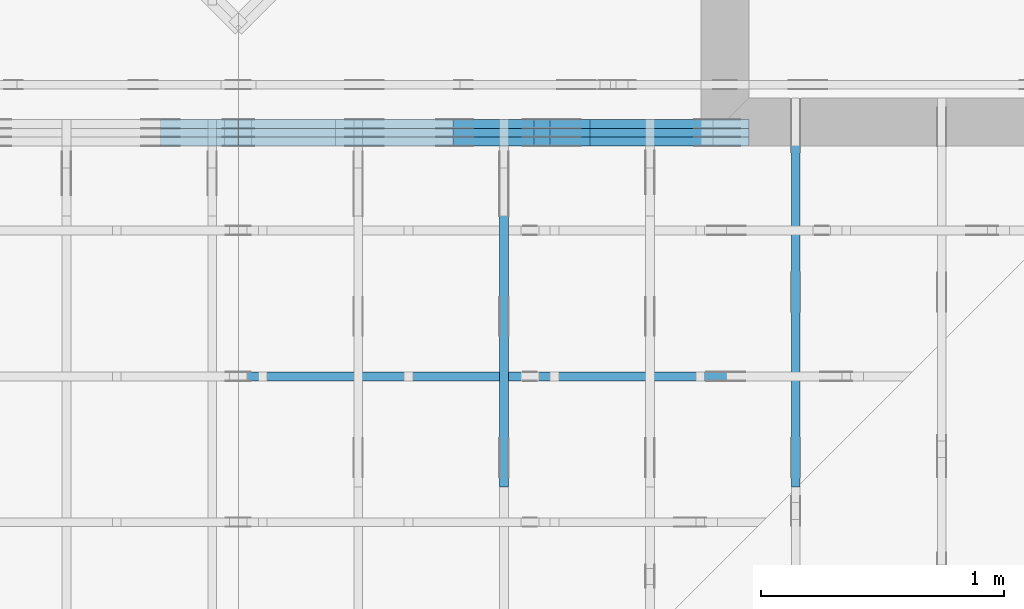
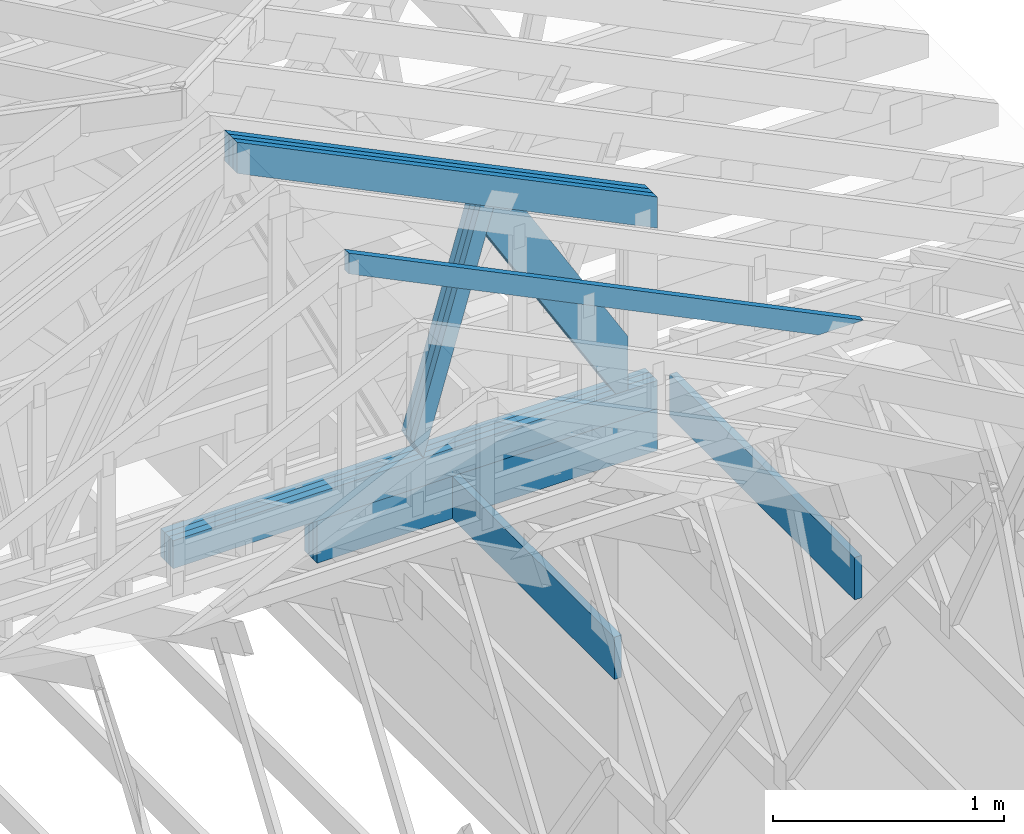
# One storey, part 36 of 159: 18 members, 4 elements without a shape of their own.
"""IFC2X3 building model written with IfcOpenShell, lengths in millimetres."""

import ifcopenshell
import ifcopenshell.guid

model = None  # the IFC model being written
_history = None  # IfcOwnerHistory: only IFC2X3 demands one
_inside = {}  # id of a spatial element -> (the spatial element, [elements in it])
_under = {}  # id of a project, library or spatial element -> (it, [spatial elements below it])
_declared = {}  # id of a project -> (the project, [libraries it declares])
_typed = {}  # id of a type object -> (the type object, [elements of that type])
_made_of = {}  # id of a material, layer set ... -> (it, [elements and type objects made of it])


def new_model(schema):
    """Start an empty IFC model of exactly this schema.

    Asked for "IFC4X3", IfcOpenShell would pick the latest addendum, in which some entities
    have other attributes; the version numbers below select the first issue.
    IFC2X3 requires an IfcOwnerHistory on every rooted entity: one is made here for all.
    """
    global model, _history
    if schema == "IFC4X3":
        model = ifcopenshell.file(schema_version=(4, 3, 0, 0))
    else:
        model = ifcopenshell.file(schema=schema)
    _inside.clear()
    _under.clear()
    _declared.clear()
    _typed.clear()
    _made_of.clear()
    _history = None
    if model.schema == "IFC2X3":
        org = make("IfcOrganization", Name="unknown")
        user = make(
            "IfcPersonAndOrganization",
            ThePerson=make("IfcPerson", FamilyName="unknown"),
            TheOrganization=org,
        )
        app = make(
            "IfcApplication",
            ApplicationDeveloper=org,
            Version="unknown",
            ApplicationFullName="unknown",
            ApplicationIdentifier="unknown",
        )
        _history = make(
            "IfcOwnerHistory",
            OwningUser=user,
            OwningApplication=app,
            ChangeAction="ADDED",
            CreationDate=0,
        )
    return model


def make(cls, **values):
    """One entity of the class cls with the attributes given. An attribute that is None is left unset."""
    return model.create_entity(
        cls, **{name: value for name, value in values.items() if value is not None}
    )


def rooted(cls, **values):
    """An entity with a GlobalId (a new one), such as an element, a storey or a relation."""
    return make(cls, GlobalId=ifcopenshell.guid.new(), OwnerHistory=_history, **values)


def si_unit(unit_type, name, prefix=None):
    """IfcSIUnit, for example si_unit("LENGTHUNIT", "METRE", prefix="MILLI")."""
    return make("IfcSIUnit", UnitType=unit_type, Prefix=prefix, Name=name)


def assignment(units):
    """IfcUnitAssignment: the units of a project."""
    return None if units is None else make("IfcUnitAssignment", Units=units)


def point(xyz):
    """IfcCartesianPoint."""
    return None if xyz is None else make("IfcCartesianPoint", Coordinates=xyz)


def direction(xyz):
    """IfcDirection."""
    return None if xyz is None else make("IfcDirection", DirectionRatios=xyz)


def frame(location, z_axis=None, x_axis=None):
    """IfcAxis2Placement3D, a coordinate frame: its origin and axes. An axis left out is left unset."""
    return make(
        "IfcAxis2Placement3D",
        Location=point(location),
        Axis=direction(z_axis),
        RefDirection=direction(x_axis),
    )


def frame_2d(location, x_axis=None):
    """IfcAxis2Placement2D, a coordinate frame in the plane: its origin and x axis."""
    return make(
        "IfcAxis2Placement2D", Location=point(location), RefDirection=direction(x_axis)
    )


def origin():
    """The frame at (0, 0, 0) with its axes left unset."""
    return frame((0.0, 0.0, 0.0))


def origin_with_axes():
    """The frame at (0, 0, 0) with the z axis (0, 0, 1) and the x axis (1, 0, 0) written out."""
    return frame((0.0, 0.0, 0.0), z_axis=(0.0, 0.0, 1.0), x_axis=(1.0, 0.0, 0.0))


def origin_2d():
    """The frame at (0, 0) in the plane with its x axis left unset."""
    return frame_2d((0.0, 0.0))


def place(relative_to, where):
    """IfcLocalPlacement: puts the frame where relative to a parent placement (None: the world)."""
    return make(
        "IfcLocalPlacement", PlacementRelTo=relative_to, RelativePlacement=where
    )


def context(
    kind, dimensions, precision=None, world=None, true_north=None, identifier=None
):
    """IfcGeometricRepresentationContext, for example the 3D "Model" context."""
    return make(
        "IfcGeometricRepresentationContext",
        ContextIdentifier=identifier,
        ContextType=kind,
        CoordinateSpaceDimension=dimensions,
        Precision=precision,
        WorldCoordinateSystem=world,
        TrueNorth=true_north,
    )


def project(units=None, contexts=None):
    """IfcProject with its units and contexts."""
    return rooted(
        "IfcProject",
        Name="project",
        RepresentationContexts=contexts,
        UnitsInContext=assignment(units),
    )


def spatial(cls, under=None, at=None, **own):
    """A site, building, storey or space (cls), placed at a placement, below another one or the project."""
    s = rooted(cls, ObjectPlacement=at, **own)
    if under is not None:
        _under.setdefault(under.id(), (under, []))[1].append(s)
    return s


def faces_of(points, faces, orient=None, outer=None):
    """IfcFace entities. A face is a list of loops; a loop is a list of indices into points, from 0.

    orient and outer hold one flag for each loop. By default every Orientation is true, the
    first loop of a face is its IfcFaceOuterBound and the others are IfcFaceBound.
    """
    made = []
    for i, loops in enumerate(faces):
        bounds = []
        for j, loop in enumerate(loops):
            is_outer = j == 0 if outer is None else outer[i][j]
            bounds.append(
                make(
                    "IfcFaceOuterBound" if is_outer else "IfcFaceBound",
                    Bound=make("IfcPolyLoop", Polygon=[points[k] for k in loop]),
                    Orientation=True if orient is None else orient[i][j],
                )
            )
        made.append(make("IfcFace", Bounds=bounds))
    return made


def faceted_brep(points, faces, orient=None, outer=None, voids=None):
    """IfcFacetedBrep: a solid bounded by flat faces; with voids (closed shells), ...WithVoids."""
    shared = [point(p) for p in points]
    hull = make("IfcClosedShell", CfsFaces=faces_of(shared, faces, orient, outer))
    if voids is None:
        return make("IfcFacetedBrep", Outer=hull)
    return make(
        "IfcFacetedBrepWithVoids",
        Outer=hull,
        Voids=[
            make(cls, CfsFaces=faces_of(shared, fs, o, b)) for cls, fs, o, b in voids
        ],
    )


def shape(context_of_items, identifier, shape_type, items):
    """IfcShapeRepresentation: the items that make up one representation, for example the "Body"."""
    return make(
        "IfcShapeRepresentation",
        ContextOfItems=context_of_items,
        RepresentationIdentifier=identifier,
        RepresentationType=shape_type,
        Items=items,
    )


def made_of(thing, what):
    """Note that an element or type object is made of a material, layer set ...; save() writes the relation."""
    if what is not None:
        _made_of.setdefault(what.id(), (what, []))[1].append(thing)
    return thing


def element(
    cls,
    number,
    at=None,
    inside=None,
    cuts=None,
    type_object=None,
    material=None,
    context=None,
    identifier="Body",
    shape_type=None,
    held_by="IfcProductDefinitionShape",
    body=None,
    shapes=None,
    **own,
):
    """One element of the class cls, such as IfcWall. Its Tag is "e" and its number.

    at: its placement. inside: the storey or other place that contains it. cuts: it is an
    opening in that element (IfcRelVoidsElement). A single representation is given by context,
    identifier, shape_type and body (its items); several are given by shapes. held_by: the class
    of the entity that holds the representations. save() writes the other relations.
    """
    e = rooted(cls, Tag="e%d" % number, ObjectPlacement=at, **own)
    if body is not None:
        shapes = [shape(context, identifier, shape_type, body)]
    if shapes is not None:
        e.Representation = make(held_by, Representations=shapes)
    if inside is not None:
        _inside.setdefault(inside.id(), (inside, []))[1].append(e)
    if cuts is not None:
        rooted(
            "IfcRelVoidsElement", RelatingBuildingElement=cuts, RelatedOpeningElement=e
        )
    if type_object is not None:
        _typed.setdefault(type_object.id(), (type_object, []))[1].append(e)
    return made_of(e, material)


def aggregate(whole, parts):
    """IfcRelAggregates: a whole, such as a stair, and the parts it consists of."""
    return rooted("IfcRelAggregates", RelatingObject=whole, RelatedObjects=parts)


def save(model, path):
    """Write the relations noted so far, then the file.

    IfcRelAggregates (storeys below a building ...), IfcRelContainedInSpatialStructure (elements
    in a storey), IfcRelDefinesByType, IfcRelAssociatesMaterial and IfcRelDeclares: one each for
    every whole, place, type object, material and project.
    """
    for whole, parts in _under.values():
        aggregate(whole, parts)
    for where, things in _inside.values():
        rooted(
            "IfcRelContainedInSpatialStructure",
            RelatedElements=things,
            RelatingStructure=where,
        )
    for kind, things in _typed.values():
        rooted("IfcRelDefinesByType", RelatedObjects=things, RelatingType=kind)
    for what, things in _made_of.values():
        rooted("IfcRelAssociatesMaterial", RelatedObjects=things, RelatingMaterial=what)
    for by, libraries in _declared.values():
        rooted("IfcRelDeclares", RelatingContext=by, RelatedDefinitions=libraries)
    model.write(path)


model = new_model("IFC2X3")

# Units and contexts
model_context = context("Model", 3, precision=1e-05, world=origin())
plan_context = context("Plan", 2, precision=1e-05, world=origin_2d())
ifc_project = project(units=[si_unit("LENGTHUNIT", "METRE", prefix="MILLI"), si_unit("AREAUNIT", "SQUARE_METRE"), si_unit("VOLUMEUNIT", "CUBIC_METRE"), si_unit("SOLIDANGLEUNIT", "STERADIAN"), si_unit("PLANEANGLEUNIT", "RADIAN"), si_unit("MASSUNIT", "GRAM"), si_unit("TIMEUNIT", "SECOND"), si_unit("THERMODYNAMICTEMPERATUREUNIT", "DEGREE_CELSIUS"), si_unit("LUMINOUSINTENSITYUNIT", "LUMEN")], contexts=[model_context, plan_context])

# Site, building, storey
site_placement = place(None, origin_with_axes())
site = spatial("IfcSite", under=ifc_project, at=site_placement, CompositionType="ELEMENT")
building_placement = place(site_placement, origin_with_axes())
building = spatial("IfcBuilding", under=site, at=building_placement, Name="Plan 1", CompositionType="ELEMENT")
storey_placement = place(building_placement, origin_with_axes())
storey = spatial("IfcBuildingStorey", under=building, at=storey_placement, Name="Etasje 1", CompositionType="ELEMENT", Elevation=0.0)

# Assembly, members
assembly_1_placement = place(storey_placement, frame((10700.012663101485, 8801.999999990367, 0.0), z_axis=(0.0, -1.0, 6.123031769111886e-17), x_axis=(1.0, 0.0, 0.0)))
assembly_1 = element("IfcElementAssembly", 1, at=assembly_1_placement, inside=storey, Name="T8 (1)", AssemblyPlace="FACTORY", PredefinedType="TRUSS")
member_1_placement = place(assembly_1_placement, frame((3835.1210564629464, 2230.548360230995, -36.0), z_axis=(0.0, 0.0, 1.0), x_axis=(0.8987940462991668, -0.4383711467890778, 0.0)))
member_1 = element("IfcMember", 2, at=member_1_placement, Name="T8-O49", context=model_context, shape_type="Brep", body=[
    faceted_brep([(2336.464097142599, 147.99998610479633, 36.0), (3.6465409266384086e-05, 147.99998610479633, 36.0), (72.1844384753058, 0.0, 36.0), (2408.648499152495, 0.0, 36.0), (3.6465409266384086e-05, 147.99998610479633, 4.4655771882347344e-21), (2336.464097142599, 147.99998610479633, 2.8612487788386906e-13), (2408.648499152495, 0.0, 2.949646256186878e-13), (72.1844384753058, 0.0, 8.839752200395996e-15), (72.18442310821183, 3.150720840494614e-05, 0.0), (72.18442310821183, 3.150720840494614e-05, 36.0), (7.105427357601002e-15, 148.00003150816158, 36.0), (7.105427357601002e-15, 148.00003150816158, -1.5777218104420236e-30), (2408.648498104886, 3.150971693405737e-05, -9.227199426203346e-29), (2408.648498104886, 3.150971693626166e-05, 36.0), (72.18442310821183, 3.150720845231247e-05, 36.0), (72.18442310821183, 3.1507208450108176e-05, -2.765285573021266e-30), (2336.4640749974906, 148.00003150899374, -2.2497274898090136e-29), (2336.4640749974906, 148.00003150899374, 36.0), (2408.648498104886, 3.1509715540778416e-05, 36.0), (2408.648498104886, 3.1509715540778416e-05, -2.1989861422548632e-29), (0.0, 148.00003150816156, 0.0), (0.0, 148.00003150816156, 36.0), (2336.4640749974906, 148.00003150899357, 36.0), (2336.4640749974906, 148.00003150899357, -9.466330862652142e-30)], [[[0, 1, 2, 3]], [[4, 5, 6, 7]], [[8, 9, 10, 11]], [[12, 13, 14, 15]], [[16, 17, 18, 19]], [[20, 21, 22, 23]]]),
])
member_2_placement = place(assembly_1_placement, frame((3835.1210564629464, 2230.548360230995, -72.0), z_axis=(0.0, 0.0, 1.0), x_axis=(0.8987940462991668, -0.4383711467890778, 0.0)))
member_2 = element("IfcMember", 3, at=member_2_placement, Name="T8-O49", context=model_context, shape_type="Brep", body=[
    faceted_brep([(2336.464097142599, 147.99998610479633, 36.0), (3.6465409266384086e-05, 147.99998610479633, 36.0), (72.1844384753058, 0.0, 36.0), (2408.648499152495, 0.0, 36.0), (3.6465409266384086e-05, 147.99998610479633, 4.4655771882347344e-21), (2336.464097142599, 147.99998610479633, 2.8612487788386906e-13), (2408.648499152495, 0.0, 2.949646256186878e-13), (72.1844384753058, 0.0, 8.839752200395996e-15), (72.18442310821183, 3.150720840494614e-05, 0.0), (72.18442310821183, 3.150720840494614e-05, 36.0), (7.105427357601002e-15, 148.00003150816158, 36.0), (7.105427357601002e-15, 148.00003150816158, -1.5777218104420236e-30), (2408.648498104886, 3.150971693405737e-05, -9.227199426203346e-29), (2408.648498104886, 3.150971693626166e-05, 36.0), (72.18442310821183, 3.150720845231247e-05, 36.0), (72.18442310821183, 3.1507208450108176e-05, -2.765285573021266e-30), (2336.4640749974906, 148.00003150899374, -2.2497274898090136e-29), (2336.4640749974906, 148.00003150899374, 36.0), (2408.648498104886, 3.1509715540778416e-05, 36.0), (2408.648498104886, 3.1509715540778416e-05, -2.1989861422548632e-29), (0.0, 148.00003150816156, 0.0), (0.0, 148.00003150816156, 36.0), (2336.4640749974906, 148.00003150899357, 36.0), (2336.4640749974906, 148.00003150899357, -9.466330862652142e-30)], [[[0, 1, 2, 3]], [[4, 5, 6, 7]], [[8, 9, 10, 11]], [[12, 13, 14, 15]], [[16, 17, 18, 19]], [[20, 21, 22, 23]]]),
])
member_3_placement = place(assembly_1_placement, frame((3835.1210564629464, 2230.548360230995, -108.0), z_axis=(0.0, 0.0, 1.0), x_axis=(0.8987940462991668, -0.4383711467890778, 0.0)))
member_3 = element("IfcMember", 4, at=member_3_placement, Name="T8-O49", context=model_context, shape_type="Brep", body=[
    faceted_brep([(2336.464097142599, 147.99998610479633, 36.0), (3.6465409266384086e-05, 147.99998610479633, 36.0), (72.1844384753058, 0.0, 36.0), (2408.648499152495, 0.0, 36.0), (3.6465409266384086e-05, 147.99998610479633, 4.4655771882347344e-21), (2336.464097142599, 147.99998610479633, 2.8612487788386906e-13), (2408.648499152495, 0.0, 2.949646256186878e-13), (72.1844384753058, 0.0, 8.839752200395996e-15), (72.18442310821183, 3.150720840494614e-05, 0.0), (72.18442310821183, 3.150720840494614e-05, 36.0), (7.105427357601002e-15, 148.00003150816158, 36.0), (7.105427357601002e-15, 148.00003150816158, -1.5777218104420236e-30), (2408.648498104886, 3.150971693405737e-05, -9.227199426203346e-29), (2408.648498104886, 3.150971693626166e-05, 36.0), (72.18442310821183, 3.150720845231247e-05, 36.0), (72.18442310821183, 3.1507208450108176e-05, -2.765285573021266e-30), (2336.4640749974906, 148.00003150899374, -2.2497274898090136e-29), (2336.4640749974906, 148.00003150899374, 36.0), (2408.648498104886, 3.1509715540778416e-05, 36.0), (2408.648498104886, 3.1509715540778416e-05, -2.1989861422548632e-29), (0.0, 148.00003150816156, 0.0), (0.0, 148.00003150816156, 36.0), (2336.4640749974906, 148.00003150899357, 36.0), (2336.4640749974906, 148.00003150899357, -9.466330862652142e-30)], [[[0, 1, 2, 3]], [[4, 5, 6, 7]], [[8, 9, 10, 11]], [[12, 13, 14, 15]], [[16, 17, 18, 19]], [[20, 21, 22, 23]]]),
])
member_4_placement = place(assembly_1_placement, frame((6000.0, 371.0, -36.0), z_axis=(0.0, 0.0, 1.0), x_axis=(-1.0, 1.2246063538223773e-16, 0.0)))
member_4 = element("IfcMember", 5, at=member_4_placement, Name="T8-U41", context=model_context, shape_type="Brep", body=[
    faceted_brep([(2420.0, 148.0000000000003, 36.0), (0.0, 148.0000000000003, 36.0), (0.0, 0.0, 36.0), (2420.0, 0.0, 36.0), (0.0, 148.0000000000003, 0.0), (2420.0, 148.0000000000003, 2.963547376250153e-13), (2420.0, 0.0, 2.963547376250153e-13), (0.0, 0.0, 0.0), (1.8189894035458565e-12, 0.0, 0.0), (1.8211936949827368e-12, -2.6993892992798474e-31, 36.0), (1.839317869019308e-12, 148.0, 36.0), (1.8371135775824277e-12, 148.0, -1.1097489341483817e-30), (2419.9999999999995, -4.445321064375233e-13, 6.550478865153457e-29), (2419.9999999999995, -4.42327815000643e-13, 36.0), (1.8189894035458565e-12, 2.204291436879475e-15, 36.0), (1.8189894035458565e-12, -8.041208815728046e-28, 4.92365770407654e-44), (2419.9999999999995, 148.00000000000065, 0.0), (2419.9999999999995, 148.00000000000065, 36.0), (2419.9999999999995, 6.252776074688882e-13, 36.0), (2419.9999999999995, 6.252776074688882e-13, 0.0), (1.8189894035458565e-12, 148.0, 0.0), (1.8189894035458565e-12, 148.0, 36.0), (2419.9999999999995, 148.0000000000004, 36.0), (2419.9999999999995, 148.0000000000004, -1.5777218104420236e-29)], [[[0, 1, 2, 3]], [[4, 5, 6, 7]], [[8, 9, 10, 11]], [[12, 13, 14, 15]], [[16, 17, 18, 19]], [[20, 21, 22, 23]]]),
])
member_5_placement = place(assembly_1_placement, frame((6000.0, 371.0, -72.0), z_axis=(0.0, 0.0, 1.0), x_axis=(-1.0, 1.2246063538223773e-16, 0.0)))
member_5 = element("IfcMember", 6, at=member_5_placement, Name="T8-U41", context=model_context, shape_type="Brep", body=[
    faceted_brep([(2420.0, 148.0000000000003, 36.0), (0.0, 148.0000000000003, 36.0), (0.0, 0.0, 36.0), (2420.0, 0.0, 36.0), (0.0, 148.0000000000003, 0.0), (2420.0, 148.0000000000003, 2.963547376250153e-13), (2420.0, 0.0, 2.963547376250153e-13), (0.0, 0.0, 0.0), (1.8189894035458565e-12, 0.0, 0.0), (1.8211936949827368e-12, -2.6993892992798474e-31, 36.0), (1.839317869019308e-12, 148.0, 36.0), (1.8371135775824277e-12, 148.0, -1.1097489341483817e-30), (2419.9999999999995, -4.445321064375233e-13, 6.550478865153457e-29), (2419.9999999999995, -4.42327815000643e-13, 36.0), (1.8189894035458565e-12, 2.204291436879475e-15, 36.0), (1.8189894035458565e-12, -8.041208815728046e-28, 4.92365770407654e-44), (2419.9999999999995, 148.00000000000065, 0.0), (2419.9999999999995, 148.00000000000065, 36.0), (2419.9999999999995, 6.252776074688882e-13, 36.0), (2419.9999999999995, 6.252776074688882e-13, 0.0), (1.8189894035458565e-12, 148.0, 0.0), (1.8189894035458565e-12, 148.0, 36.0), (2419.9999999999995, 148.0000000000004, 36.0), (2419.9999999999995, 148.0000000000004, -1.5777218104420236e-29)], [[[0, 1, 2, 3]], [[4, 5, 6, 7]], [[8, 9, 10, 11]], [[12, 13, 14, 15]], [[16, 17, 18, 19]], [[20, 21, 22, 23]]]),
])
member_6_placement = place(assembly_1_placement, frame((6000.0, 371.0, -108.0), z_axis=(0.0, 0.0, 1.0), x_axis=(-1.0, 1.2246063538223773e-16, 0.0)))
member_6 = element("IfcMember", 7, at=member_6_placement, Name="T8-U41", context=model_context, shape_type="Brep", body=[
    faceted_brep([(2420.0, 148.0000000000003, 36.0), (0.0, 148.0000000000003, 36.0), (0.0, 0.0, 36.0), (2420.0, 0.0, 36.0), (0.0, 148.0000000000003, 0.0), (2420.0, 148.0000000000003, 2.963547376250153e-13), (2420.0, 0.0, 2.963547376250153e-13), (0.0, 0.0, 0.0), (1.8189894035458565e-12, 0.0, 0.0), (1.8211936949827368e-12, -2.6993892992798474e-31, 36.0), (1.839317869019308e-12, 148.0, 36.0), (1.8371135775824277e-12, 148.0, -1.1097489341483817e-30), (2419.9999999999995, -4.445321064375233e-13, 6.550478865153457e-29), (2419.9999999999995, -4.42327815000643e-13, 36.0), (1.8189894035458565e-12, 2.204291436879475e-15, 36.0), (1.8189894035458565e-12, -8.041208815728046e-28, 4.92365770407654e-44), (2419.9999999999995, 148.00000000000065, 0.0), (2419.9999999999995, 148.00000000000065, 36.0), (2419.9999999999995, 6.252776074688882e-13, 36.0), (2419.9999999999995, 6.252776074688882e-13, 0.0), (1.8189894035458565e-12, 148.0, 0.0), (1.8189894035458565e-12, 148.0, 36.0), (2419.9999999999995, 148.0000000000004, 36.0), (2419.9999999999995, 148.0000000000004, -1.5777218104420236e-29)], [[[0, 1, 2, 3]], [[4, 5, 6, 7]], [[8, 9, 10, 11]], [[12, 13, 14, 15]], [[16, 17, 18, 19]], [[20, 21, 22, 23]]]),
])
member_7_placement = place(assembly_1_placement, frame((4300.0, -1.4210854715202004e-14, -36.0), z_axis=(0.0, 0.0, 1.0), x_axis=(1.0, 0.0, 0.0)))
member_7 = element("IfcMember", 8, at=member_7_placement, Name="T8-U15", context=model_context, shape_type="Brep", body=[
    faceted_brep([(1700.0, 223.0, 36.0), (0.0, 223.0, 36.0), (0.0, 1.4210854715202004e-14, 36.0), (1700.0, 1.4210854715202004e-14, 36.0), (0.0, 223.0, 0.0), (1700.0, 223.0, 2.0818308014980413e-13), (1700.0, 1.4210854715202004e-14, 2.0818308014980413e-13), (0.0, 1.4210854715202004e-14, 0.0), (9.094947017729282e-13, 1.4210854715202002e-14, 0.0), (9.116989932098085e-13, 1.4210854715202002e-14, 36.0), (9.390077149000475e-13, 223.0, 36.0), (9.368034234631673e-13, 223.0, -1.6721217048316832e-30), (1699.9999999999982, -2.9806376550950384e-13, 1.825053905435808e-29), (1699.9999999999982, -2.9585947407262356e-13, 36.0), (9.094947017729282e-13, 1.6415146152082122e-14, 36.0), (9.094947017729282e-13, 1.4210854715201843e-14, 9.80908925027372e-45), (1699.9999999999982, 223.0, 0.0), (1699.9999999999982, 223.0, 36.0), (1699.9999999999982, 0.0, 36.0), (1699.9999999999982, 0.0, 0.0), (9.094947017729282e-13, 223.0, 0.0), (9.094947017729282e-13, 223.0, 36.0), (1699.9999999999982, 222.9999999999999, 36.0), (1699.9999999999982, 222.9999999999999, -6.310887241768095e-30)], [[[0, 1, 2, 3]], [[4, 5, 6, 7]], [[8, 9, 10, 11]], [[12, 13, 14, 15]], [[16, 17, 18, 19]], [[20, 21, 22, 23]]]),
])
member_8_placement = place(assembly_1_placement, frame((4300.0, -1.4210854715202004e-14, -72.0), z_axis=(0.0, 0.0, 1.0), x_axis=(1.0, 0.0, 0.0)))
member_8 = element("IfcMember", 9, at=member_8_placement, Name="T8-U15", context=model_context, shape_type="Brep", body=[
    faceted_brep([(1700.0, 223.0, 36.0), (0.0, 223.0, 36.0), (0.0, 1.4210854715202004e-14, 36.0), (1700.0, 1.4210854715202004e-14, 36.0), (0.0, 223.0, 0.0), (1700.0, 223.0, 2.0818308014980413e-13), (1700.0, 1.4210854715202004e-14, 2.0818308014980413e-13), (0.0, 1.4210854715202004e-14, 0.0), (9.094947017729282e-13, 1.4210854715202002e-14, 0.0), (9.116989932098085e-13, 1.4210854715202002e-14, 36.0), (9.390077149000475e-13, 223.0, 36.0), (9.368034234631673e-13, 223.0, -1.6721217048316832e-30), (1699.9999999999982, -2.9806376550950384e-13, 1.825053905435808e-29), (1699.9999999999982, -2.9585947407262356e-13, 36.0), (9.094947017729282e-13, 1.6415146152082122e-14, 36.0), (9.094947017729282e-13, 1.4210854715201843e-14, 9.80908925027372e-45), (1699.9999999999982, 223.0, 0.0), (1699.9999999999982, 223.0, 36.0), (1699.9999999999982, 0.0, 36.0), (1699.9999999999982, 0.0, 0.0), (9.094947017729282e-13, 223.0, 0.0), (9.094947017729282e-13, 223.0, 36.0), (1699.9999999999982, 222.9999999999999, 36.0), (1699.9999999999982, 222.9999999999999, -6.310887241768095e-30)], [[[0, 1, 2, 3]], [[4, 5, 6, 7]], [[8, 9, 10, 11]], [[12, 13, 14, 15]], [[16, 17, 18, 19]], [[20, 21, 22, 23]]]),
])
member_9_placement = place(assembly_1_placement, frame((4300.0, -1.4210854715202004e-14, -108.0), z_axis=(0.0, 0.0, 1.0), x_axis=(1.0, 0.0, 0.0)))
member_9 = element("IfcMember", 10, at=member_9_placement, Name="T8-U15", context=model_context, shape_type="Brep", body=[
    faceted_brep([(1700.0, 223.0, 36.0), (0.0, 223.0, 36.0), (0.0, 1.4210854715202004e-14, 36.0), (1700.0, 1.4210854715202004e-14, 36.0), (0.0, 223.0, 0.0), (1700.0, 223.0, 2.0818308014980413e-13), (1700.0, 1.4210854715202004e-14, 2.0818308014980413e-13), (0.0, 1.4210854715202004e-14, 0.0), (9.094947017729282e-13, 1.4210854715202002e-14, 0.0), (9.116989932098085e-13, 1.4210854715202002e-14, 36.0), (9.390077149000475e-13, 223.0, 36.0), (9.368034234631673e-13, 223.0, -1.6721217048316832e-30), (1699.9999999999982, -2.9806376550950384e-13, 1.825053905435808e-29), (1699.9999999999982, -2.9585947407262356e-13, 36.0), (9.094947017729282e-13, 1.6415146152082122e-14, 36.0), (9.094947017729282e-13, 1.4210854715201843e-14, 9.80908925027372e-45), (1699.9999999999982, 223.0, 0.0), (1699.9999999999982, 223.0, 36.0), (1699.9999999999982, 0.0, 36.0), (1699.9999999999982, 0.0, 0.0), (9.094947017729282e-13, 223.0, 0.0), (9.094947017729282e-13, 223.0, 36.0), (1699.9999999999982, 222.9999999999999, 36.0), (1699.9999999999982, 222.9999999999999, -6.310887241768095e-30)], [[[0, 1, 2, 3]], [[4, 5, 6, 7]], [[8, 9, 10, 11]], [[12, 13, 14, 15]], [[16, 17, 18, 19]], [[20, 21, 22, 23]]]),
])
member_10_placement = place(assembly_1_placement, frame((5115.9731050904375, 1605.835110040617, -36.0), z_axis=(0.0, 0.0, 1.0), x_axis=(-0.28091609738555856, -0.9597323305118294, 0.0)))
member_10 = element("IfcMember", 11, at=member_10_placement, Name="T8-D41", context=model_context, shape_type="Brep", body=[
    faceted_brep([(1265.2780096671472, 73.0000782021807, 36.0), (12.458591555184285, 73.0000782021807, 36.0), (1.4864697732264176e-05, 4.544657258520601e-05, 36.0), (1184.9849979052592, 4.544657258520601e-05, 36.0), (12.458591555184285, 73.0000782021807, 1.5256870378156488e-15), (1265.2780096671472, 73.0000782021807, 1.5494674899901198e-13), (1184.9849979052592, 4.544657258520601e-05, 1.4511401576189768e-13), (1.4864697732264176e-05, 4.544657258520601e-05, 1.8203403290579792e-21), (7.113886156478325e-16, 2.728362695677113e-12, -4.418835803974857e-32), (2.8842627638355983e-15, 2.727991860572463e-12, 36.0), (12.458596675764028, 73.00000000000456, 36.0), (12.458596675764026, 73.00000000000456, 2.0294486788980554e-30), (1184.9850036290459, 4.0585686484134427e-13, -2.4850744771356995e-29), (1184.9850036290459, 4.0806115627822455e-13, 36.0), (4.320516564825666e-30, 2.730688396755665e-12, 36.0), (0.0, 2.7284841053187847e-12, 0.0), (1265.2780325571248, 73.00000000000034, 4.417621069237666e-29), (1265.2780325571248, 73.00000000000034, 36.0), (1184.9850036290463, -4.547473508864641e-13, 36.0), (1184.9850036290463, -4.547473508864641e-13, 3.7865323450608567e-29), (12.458596675764056, 73.00000000000455, 0.0), (12.458596675764056, 73.00000000000455, 36.0), (1265.2780325571243, 73.00000000000085, 36.0), (1265.2780325571243, 73.00000000000087, -3.944304526105059e-30)], [[[0, 1, 2, 3]], [[4, 5, 6, 7]], [[8, 9, 10, 11]], [[12, 13, 14, 15]], [[16, 17, 18, 19]], [[20, 21, 22, 23]]]),
])
member_11_placement = place(assembly_1_placement, frame((5115.9731050904375, 1605.835110040617, -72.0), z_axis=(0.0, 0.0, 1.0), x_axis=(-0.28091609738555856, -0.9597323305118294, 0.0)))
member_11 = element("IfcMember", 12, at=member_11_placement, Name="T8-D41", context=model_context, shape_type="Brep", body=[
    faceted_brep([(1265.2780096671472, 73.0000782021807, 36.0), (12.458591555184285, 73.0000782021807, 36.0), (1.4864697732264176e-05, 4.544657258520601e-05, 36.0), (1184.9849979052592, 4.544657258520601e-05, 36.0), (12.458591555184285, 73.0000782021807, 1.5256870378156488e-15), (1265.2780096671472, 73.0000782021807, 1.5494674899901198e-13), (1184.9849979052592, 4.544657258520601e-05, 1.4511401576189768e-13), (1.4864697732264176e-05, 4.544657258520601e-05, 1.8203403290579792e-21), (7.113886156478325e-16, 2.728362695677113e-12, -4.418835803974857e-32), (2.8842627638355983e-15, 2.727991860572463e-12, 36.0), (12.458596675764028, 73.00000000000456, 36.0), (12.458596675764026, 73.00000000000456, 2.0294486788980554e-30), (1184.9850036290459, 4.0585686484134427e-13, -2.4850744771356995e-29), (1184.9850036290459, 4.0806115627822455e-13, 36.0), (4.320516564825666e-30, 2.730688396755665e-12, 36.0), (0.0, 2.7284841053187847e-12, 0.0), (1265.2780325571248, 73.00000000000034, 4.417621069237666e-29), (1265.2780325571248, 73.00000000000034, 36.0), (1184.9850036290463, -4.547473508864641e-13, 36.0), (1184.9850036290463, -4.547473508864641e-13, 3.7865323450608567e-29), (12.458596675764056, 73.00000000000455, 0.0), (12.458596675764056, 73.00000000000455, 36.0), (1265.2780325571243, 73.00000000000085, 36.0), (1265.2780325571243, 73.00000000000087, -3.944304526105059e-30)], [[[0, 1, 2, 3]], [[4, 5, 6, 7]], [[8, 9, 10, 11]], [[12, 13, 14, 15]], [[16, 17, 18, 19]], [[20, 21, 22, 23]]]),
])
member_12_placement = place(assembly_1_placement, frame((5115.9731050904375, 1605.835110040617, -107.99999999999999), z_axis=(0.0, 0.0, 1.0), x_axis=(-0.28091609738555856, -0.9597323305118294, 0.0)))
member_12 = element("IfcMember", 13, at=member_12_placement, Name="T8-D41", context=model_context, shape_type="Brep", body=[
    faceted_brep([(1265.2780096671472, 73.0000782021807, 36.0), (12.458591555184285, 73.0000782021807, 36.0), (1.4864697732264176e-05, 4.544657258520601e-05, 36.0), (1184.9849979052592, 4.544657258520601e-05, 36.0), (12.458591555184285, 73.0000782021807, 1.5256870378156488e-15), (1265.2780096671472, 73.0000782021807, 1.5494674899901198e-13), (1184.9849979052592, 4.544657258520601e-05, 1.4511401576189768e-13), (1.4864697732264176e-05, 4.544657258520601e-05, 1.8203403290579792e-21), (7.113886156478325e-16, 2.728362695677113e-12, -4.418835803974857e-32), (2.8842627638355983e-15, 2.727991860572463e-12, 36.0), (12.458596675764028, 73.00000000000456, 36.0), (12.458596675764026, 73.00000000000456, 2.0294486788980554e-30), (1184.9850036290459, 4.0585686484134427e-13, -2.4850744771356995e-29), (1184.9850036290459, 4.0806115627822455e-13, 36.0), (4.320516564825666e-30, 2.730688396755665e-12, 36.0), (0.0, 2.7284841053187847e-12, 0.0), (1265.2780325571248, 73.00000000000034, 4.417621069237666e-29), (1265.2780325571248, 73.00000000000034, 36.0), (1184.9850036290463, -4.547473508864641e-13, 36.0), (1184.9850036290463, -4.547473508864641e-13, 3.7865323450608567e-29), (12.458596675764056, 73.00000000000455, 0.0), (12.458596675764056, 73.00000000000455, 36.0), (1265.2780325571243, 73.00000000000085, 36.0), (1265.2780325571243, 73.00000000000087, -3.944304526105059e-30)], [[[0, 1, 2, 3]], [[4, 5, 6, 7]], [[8, 9, 10, 11]], [[12, 13, 14, 15]], [[16, 17, 18, 19]], [[20, 21, 22, 23]]]),
])
member_13_placement = place(assembly_1_placement, frame((5097.788816019909, 1522.1922030001756, -36.0), z_axis=(0.0, 0.0, 1.0), x_axis=(0.516961017765549, -0.856008940438596, 0.0)))
member_13 = element("IfcMember", 14, at=member_13_placement, Name="T8-D4", context=model_context, shape_type="Brep", body=[
    faceted_brep([(1131.0744626921964, 198.0000097794191, 36.0), (153.198367006559, 198.0000097794191, 36.0), (0.0, 98.99998864838926, 36.0), (90.89658786448695, 0.0, 36.0), (1344.8367339467122, 0.0, 36.0), (1375.3285992118608, 50.49002355900211, 36.0), (153.198367006559, 198.0000097794191, 1.876076936314446e-14), (1131.0744626921964, 198.0000097794191, 1.385120973659095e-13), (1375.3285992118608, 50.49002355900211, 1.6842361411884746e-13), (1344.8367339467122, 0.0, 1.6468956092448776e-13), (90.89658786448695, 0.0, 1.1131253903962471e-14), (0.0, 98.99998864838926, 0.0), (4.559440937867976e-05, 99.00002355920148, -2.3665827156630354e-30), (4.559440937867976e-05, 99.00002355920148, 36.0), (153.19850142646533, 198.00002355900045, 36.0), (153.19850142646533, 198.00002355900045, -2.3665827156630354e-30), (90.89655853555792, 2.355899959383123e-05, -7.88860905221012e-31), (90.89655853555792, 2.355899959383123e-05, 36.0), (4.5594409357363475e-05, 99.00002355920151, 36.0), (4.5594409357363475e-05, 99.00002355920151, -1.7516230804060213e-46), (1344.836672604636, 2.3559002673554502e-05, 3.461723150273282e-29), (1344.836672604636, 2.3559002675758794e-05, 36.0), (90.89655853555792, 2.3558999564928604e-05, 36.0), (90.89655853555792, 2.3558999562724312e-05, 2.3397541729953482e-30), (1375.3285992118613, 50.4900235590012, 0.0), (1375.3285992118613, 50.4900235590012, 36.0), (1344.836672604636, 2.3559003238915466e-05, 36.0), (1344.836672604636, 2.3559003238915466e-05, 0.0), (1131.0744398752972, 198.00002355900324, 0.0), (1131.0744398752972, 198.00002355900324, 36.0), (1375.3285992118613, 50.4900235590012, 36.0), (1375.3285992118613, 50.4900235590012, -6.310887241768095e-30), (153.19850142646533, 198.00002355900054, 3.1554436208840472e-30), (153.19850142646533, 198.00002355900054, 36.0), (1131.0744398752975, 198.00002355900352, 36.0), (1131.0744398752975, 198.00002355900352, 1.8932661725304283e-29)], [[[0, 1, 2, 3, 4, 5]], [[6, 7, 8, 9, 10, 11]], [[12, 13, 14, 15]], [[16, 17, 18, 19]], [[20, 21, 22, 23]], [[24, 25, 26, 27]], [[28, 29, 30, 31]], [[32, 33, 34, 35]]]),
])
member_14_placement = place(assembly_1_placement, frame((5097.788816019909, 1522.1922030001756, -72.0), z_axis=(0.0, 0.0, 1.0), x_axis=(0.516961017765549, -0.856008940438596, 0.0)))
member_14 = element("IfcMember", 15, at=member_14_placement, Name="T8-D4", context=model_context, shape_type="Brep", body=[
    faceted_brep([(1131.0744626921964, 198.0000097794191, 36.0), (153.198367006559, 198.0000097794191, 36.0), (0.0, 98.99998864838926, 36.0), (90.89658786448695, 0.0, 36.0), (1344.8367339467122, 0.0, 36.0), (1375.3285992118608, 50.49002355900211, 36.0), (153.198367006559, 198.0000097794191, 1.876076936314446e-14), (1131.0744626921964, 198.0000097794191, 1.385120973659095e-13), (1375.3285992118608, 50.49002355900211, 1.6842361411884746e-13), (1344.8367339467122, 0.0, 1.6468956092448776e-13), (90.89658786448695, 0.0, 1.1131253903962471e-14), (0.0, 98.99998864838926, 0.0), (4.559440937867976e-05, 99.00002355920148, -2.3665827156630354e-30), (4.559440937867976e-05, 99.00002355920148, 36.0), (153.19850142646533, 198.00002355900045, 36.0), (153.19850142646533, 198.00002355900045, -2.3665827156630354e-30), (90.89655853555792, 2.355899959383123e-05, -7.88860905221012e-31), (90.89655853555792, 2.355899959383123e-05, 36.0), (4.5594409357363475e-05, 99.00002355920151, 36.0), (4.5594409357363475e-05, 99.00002355920151, -1.7516230804060213e-46), (1344.836672604636, 2.3559002673554502e-05, 3.461723150273282e-29), (1344.836672604636, 2.3559002675758794e-05, 36.0), (90.89655853555792, 2.3558999564928604e-05, 36.0), (90.89655853555792, 2.3558999562724312e-05, 2.3397541729953482e-30), (1375.3285992118613, 50.4900235590012, 0.0), (1375.3285992118613, 50.4900235590012, 36.0), (1344.836672604636, 2.3559003238915466e-05, 36.0), (1344.836672604636, 2.3559003238915466e-05, 0.0), (1131.0744398752972, 198.00002355900324, 0.0), (1131.0744398752972, 198.00002355900324, 36.0), (1375.3285992118613, 50.4900235590012, 36.0), (1375.3285992118613, 50.4900235590012, -6.310887241768095e-30), (153.19850142646533, 198.00002355900054, 3.1554436208840472e-30), (153.19850142646533, 198.00002355900054, 36.0), (1131.0744398752975, 198.00002355900352, 36.0), (1131.0744398752975, 198.00002355900352, 1.8932661725304283e-29)], [[[0, 1, 2, 3, 4, 5]], [[6, 7, 8, 9, 10, 11]], [[12, 13, 14, 15]], [[16, 17, 18, 19]], [[20, 21, 22, 23]], [[24, 25, 26, 27]], [[28, 29, 30, 31]], [[32, 33, 34, 35]]]),
])
member_15_placement = place(assembly_1_placement, frame((5097.788816019909, 1522.1922030001756, -108.0), z_axis=(0.0, 0.0, 1.0), x_axis=(0.516961017765549, -0.856008940438596, 0.0)))
member_15 = element("IfcMember", 16, at=member_15_placement, Name="T8-D4", context=model_context, shape_type="Brep", body=[
    faceted_brep([(1131.0744626921964, 198.0000097794191, 36.0), (153.198367006559, 198.0000097794191, 36.0), (0.0, 98.99998864838926, 36.0), (90.89658786448695, 0.0, 36.0), (1344.8367339467122, 0.0, 36.0), (1375.3285992118608, 50.49002355900211, 36.0), (153.198367006559, 198.0000097794191, 1.876076936314446e-14), (1131.0744626921964, 198.0000097794191, 1.385120973659095e-13), (1375.3285992118608, 50.49002355900211, 1.6842361411884746e-13), (1344.8367339467122, 0.0, 1.6468956092448776e-13), (90.89658786448695, 0.0, 1.1131253903962471e-14), (0.0, 98.99998864838926, 0.0), (4.559440937867976e-05, 99.00002355920148, -2.3665827156630354e-30), (4.559440937867976e-05, 99.00002355920148, 36.0), (153.19850142646533, 198.00002355900045, 36.0), (153.19850142646533, 198.00002355900045, -2.3665827156630354e-30), (90.89655853555792, 2.355899959383123e-05, -7.88860905221012e-31), (90.89655853555792, 2.355899959383123e-05, 36.0), (4.5594409357363475e-05, 99.00002355920151, 36.0), (4.5594409357363475e-05, 99.00002355920151, -1.7516230804060213e-46), (1344.836672604636, 2.3559002673554502e-05, 3.461723150273282e-29), (1344.836672604636, 2.3559002675758794e-05, 36.0), (90.89655853555792, 2.3558999564928604e-05, 36.0), (90.89655853555792, 2.3558999562724312e-05, 2.3397541729953482e-30), (1375.3285992118613, 50.4900235590012, 0.0), (1375.3285992118613, 50.4900235590012, 36.0), (1344.836672604636, 2.3559003238915466e-05, 36.0), (1344.836672604636, 2.3559003238915466e-05, 0.0), (1131.0744398752972, 198.00002355900324, 0.0), (1131.0744398752972, 198.00002355900324, 36.0), (1375.3285992118613, 50.4900235590012, 36.0), (1375.3285992118613, 50.4900235590012, -6.310887241768095e-30), (153.19850142646533, 198.00002355900054, 3.1554436208840472e-30), (153.19850142646533, 198.00002355900054, 36.0), (1131.0744398752975, 198.00002355900352, 36.0), (1131.0744398752975, 198.00002355900352, 1.8932661725304283e-29)], [[[0, 1, 2, 3, 4, 5]], [[6, 7, 8, 9, 10, 11]], [[12, 13, 14, 15]], [[16, 17, 18, 19]], [[20, 21, 22, 23]], [[24, 25, 26, 27]], [[28, 29, 30, 31]], [[32, 33, 34, 35]]]),
])
aggregate(assembly_1, [member_1, member_2, member_3, member_4, member_5, member_6, member_7, member_8, member_9, member_10, member_11, member_12, member_13, member_14, member_15])

# Assembly, member
assembly_2_placement = place(storey_placement, frame((16875.02226140475, -699.9989301294827, 1.1021457184401395e-15), z_axis=(-1.0, 1.836909530733566e-16, 6.123031769111886e-17), x_axis=(-1.836909530733566e-16, -1.0, 0.0)))
assembly_2 = element("IfcElementAssembly", 17, at=assembly_2_placement, inside=storey, Name="V7 (32)", AssemblyPlace="FACTORY", PredefinedType="TRUSS")
member_16_placement = place(assembly_2_placement, frame((-8099.999999999991, 223.0, -36.0), z_axis=(0.0, 0.0, 1.0), x_axis=(-1.0, 1.2246063538223773e-16, 0.0)))
member_16 = element("IfcMember", 18, at=member_16_placement, Name="V7-U16", context=model_context, shape_type="Brep", body=[
    faceted_brep([(1599.999023437509, 223.00000000001475, 36.0), (9.094947017729282e-12, 223.00000000001475, 36.0), (9.094947017729282e-12, 0.0, 36.0), (1599.999023437509, 0.0, 36.0), (9.094947017729282e-12, 223.00000000001475, 1.113772990558916e-27), (1599.999023437509, 223.00000000001475, 1.9593689702111723e-13), (1599.999023437509, 0.0, 1.9593689702111723e-13), (9.094947017729282e-12, 0.0, 1.113772990558916e-27), (0.0, 0.0, 0.0), (2.204291436880279e-15, -2.6993892992798474e-31, 36.0), (2.951301312711929e-14, 223.0, 36.0), (2.7308721690239013e-14, 223.0, -1.6721217048316832e-30), (1599.998923973917, -2.9390532726111384e-13, 3.0177808643548404e-29), (1599.998923973917, -2.9170103582423356e-13, 36.0), (4.049083948919771e-31, 2.204291436880279e-15, 36.0), (0.0, 0.0, 0.0), (1599.998923973917, 223.00000000001475, 0.0), (1599.998923973917, 223.00000000001475, 36.0), (1599.998923973917, 1.9895196601282805e-13, 36.0), (1599.998923973917, 1.9895196601282805e-13, 0.0), (0.0, 223.0, 0.0), (0.0, 223.0, 36.0), (1599.998923973917, 223.00000000001518, 36.0), (1599.998923973917, 223.00000000001518, 2.68212707775144e-29)], [[[0, 1, 2, 3]], [[4, 5, 6, 7]], [[8, 9, 10, 11]], [[12, 13, 14, 15]], [[16, 17, 18, 19]], [[20, 21, 22, 23]]]),
])
aggregate(assembly_2, [member_16])

assembly_3_placement = place(storey_placement, frame((11846.012601162385, 7836.000061939094, 1020.3543282828622), z_axis=(0.0, -1.0, 6.123031769111886e-17), x_axis=(1.0, 0.0, 0.0)))
assembly_3 = element("IfcElementAssembly", 19, at=assembly_3_placement, inside=storey, Name="Tr2 (1)", AssemblyPlace="FACTORY", PredefinedType="TRUSS")
member_17_placement = place(assembly_3_placement, frame((2711.0396102732648, 1255.1337240794057, -36.0), z_axis=(0.0, 0.0, 1.0), x_axis=(0.8987940462991671, -0.438371146789077, 0.0)))
member_17 = element("IfcMember", 20, at=member_17_placement, Name="Tr2-O82", context=model_context, shape_type="Brep", body=[
    faceted_brep([(2860.5778032001112, 98.00007151381851, 36.0), (0.0, 98.00007151381851, 36.0), (47.797812973535656, 0.0, 36.0), (2659.6481810528408, 0.0, 36.0), (0.0, 98.00007151381851, 0.0), (2860.5778032001112, 98.00007151381851, 3.503081753402114e-13), (2659.6481810528408, 0.0, 3.257022061449437e-13), (47.797812973535656, 0.0, 5.853350546620542e-15), (47.79784805767669, 6.936058980144821e-05, -7.242940726316406e-31), (47.79784805767669, 6.936058980144821e-05, 36.0), (5.437874235525442e-05, 98.00006935952388, 36.0), (5.437874235525442e-05, 98.00006935952388, -1.8491449819254168e-30), (2659.6480309677513, 6.93610277494057e-05, 5.42983620784938e-29), (2659.6480309677513, 6.936102775160999e-05, 36.0), (47.797848057676674, 6.93605897912683e-05, 36.0), (47.797848057676674, 6.936058978906401e-05, 9.758228115215563e-31), (2860.577807440076, 98.00006935983652, -5.048709793414476e-29), (2860.577807440076, 98.00006935983652, 36.0), (2659.6480309677513, 6.936102931831556e-05, 36.0), (2659.6480309677513, 6.936102931831556e-05, -5.048709793414476e-29), (5.4378742333938135e-05, 98.00006935952388, 0.0), (5.4378742333938135e-05, 98.00006935952388, 36.0), (2860.5778074400764, 98.0000693598362, 36.0), (2860.5778074400764, 98.0000693598362, 2.3665827156630354e-29)], [[[0, 1, 2, 3]], [[4, 5, 6, 7]], [[8, 9, 10, 11]], [[12, 13, 14, 15]], [[16, 17, 18, 19]], [[20, 21, 22, 23]]]),
])
aggregate(assembly_3, [member_17])

assembly_4_placement = place(storey_placement, frame((15675.02226140475, -699.9989301294845, 1.1021457184401395e-15), z_axis=(-1.0, 1.836909530733566e-16, 6.123031769111886e-17), x_axis=(-1.836909530733566e-16, -1.0, 0.0)))
assembly_4 = element("IfcElementAssembly", 21, at=assembly_4_placement, inside=storey, Name="T7 (111)", AssemblyPlace="FACTORY", PredefinedType="TRUSS")
member_18_placement = place(assembly_4_placement, frame((-9501.9990234375, 0.0, -36.0), z_axis=(0.0, 0.0, 1.0), x_axis=(1.0, 0.0, 0.0)))
member_18 = element("IfcMember", 22, at=member_18_placement, Name="T7-U19", context=model_context, shape_type="Brep", body=[
    faceted_brep([(1402.0, 223.0, 36.0), (0.0, 223.0, 36.0), (0.0, 0.0, 36.0), (1402.0, 0.0, 36.0), (0.0, 223.0, 0.0), (1402.0, 223.0, 1.716898108058973e-13), (1402.0, 0.0, 1.716898108058973e-13), (0.0, 0.0, 0.0), (9.331764886155725e-05, 0.0, 0.0), (9.331764886376154e-05, -2.6993892992798474e-31, 36.0), (9.331764889107026e-05, 223.0, 36.0), (9.331764888886597e-05, 223.0, -1.6721217180559947e-30), (1402.0000933176489, -2.575347333504538e-13, 1.576893353954587e-29), (1402.0000933176489, -2.553304419135735e-13, 36.0), (9.331764886155725e-05, 2.204274295272421e-15, 36.0), (9.331764886155725e-05, -1.714160785794428e-20, 1.0495860948785078e-36), (1402.0000933176489, 223.0, 0.0), (1402.0000933176489, 223.0, 36.0), (1402.0000933176489, 0.0, 36.0), (1402.0000933176489, 0.0, 0.0), (9.331764886155725e-05, 223.0, 0.0), (9.331764886155725e-05, 223.0, 36.0), (1402.0000933176489, 222.99999999999991, 36.0), (1402.0000933176489, 222.99999999999991, -4.733165431326071e-30)], [[[0, 1, 2, 3]], [[4, 5, 6, 7]], [[8, 9, 10, 11]], [[12, 13, 14, 15]], [[16, 17, 18, 19]], [[20, 21, 22, 23]]]),
])
aggregate(assembly_4, [member_18])

save(model, "model.ifc")
